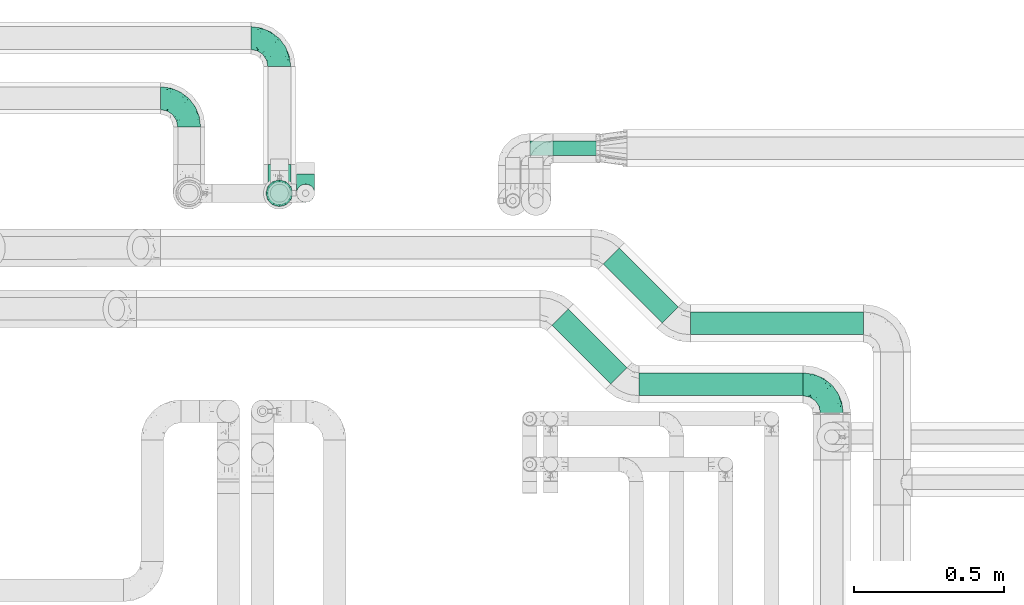
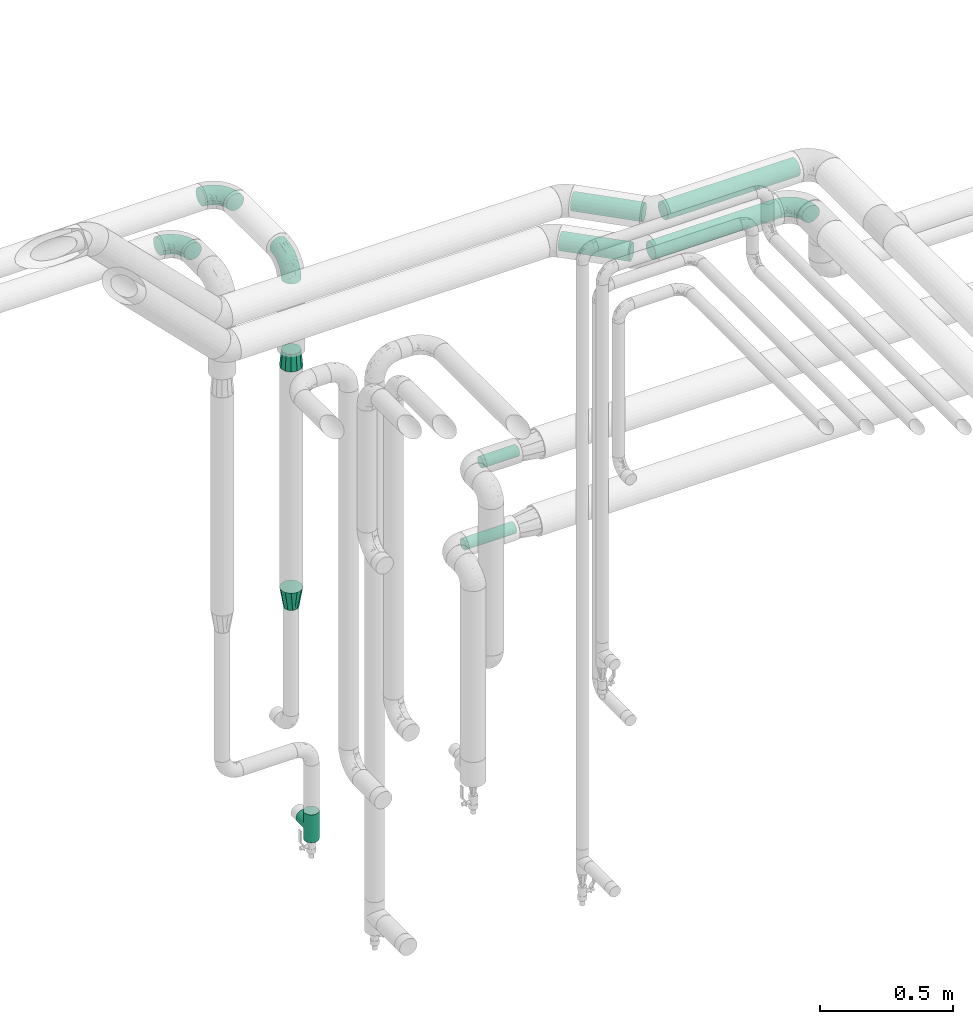
# One storey, part 685 of 827: 7 flow fittings, 6 flow segments.
"""IFC2X3 building model written with IfcOpenShell, lengths in millimetres."""

import ifcopenshell
import ifcopenshell.guid

model = None  # the IFC model being written
_history = None  # IfcOwnerHistory: only IFC2X3 demands one
_inside = {}  # id of a spatial element -> (the spatial element, [elements in it])
_under = {}  # id of a project, library or spatial element -> (it, [spatial elements below it])
_declared = {}  # id of a project -> (the project, [libraries it declares])
_typed = {}  # id of a type object -> (the type object, [elements of that type])
_made_of = {}  # id of a material, layer set ... -> (it, [elements and type objects made of it])


def new_model(schema):
    """Start an empty IFC model of exactly this schema.

    Asked for "IFC4X3", IfcOpenShell would pick the latest addendum, in which some entities
    have other attributes; the version numbers below select the first issue.
    IFC2X3 requires an IfcOwnerHistory on every rooted entity: one is made here for all.
    """
    global model, _history
    if schema == "IFC4X3":
        model = ifcopenshell.file(schema_version=(4, 3, 0, 0))
    else:
        model = ifcopenshell.file(schema=schema)
    _inside.clear()
    _under.clear()
    _declared.clear()
    _typed.clear()
    _made_of.clear()
    _history = None
    if model.schema == "IFC2X3":
        org = make("IfcOrganization", Name="unknown")
        user = make(
            "IfcPersonAndOrganization",
            ThePerson=make("IfcPerson", FamilyName="unknown"),
            TheOrganization=org,
        )
        app = make(
            "IfcApplication",
            ApplicationDeveloper=org,
            Version="unknown",
            ApplicationFullName="unknown",
            ApplicationIdentifier="unknown",
        )
        _history = make(
            "IfcOwnerHistory",
            OwningUser=user,
            OwningApplication=app,
            ChangeAction="ADDED",
            CreationDate=0,
        )
    return model


def make(cls, **values):
    """One entity of the class cls with the attributes given. An attribute that is None is left unset."""
    return model.create_entity(
        cls, **{name: value for name, value in values.items() if value is not None}
    )


def entity(cls, *values):
    """Any entity or typed value of the class cls, its attributes in the order of the schema. None: left unset."""
    e = model.create_entity(cls)
    for i, value in enumerate(values):
        if value is not None:
            e[i] = value
    return e


def rooted(cls, **values):
    """An entity with a GlobalId (a new one), such as an element, a storey or a relation."""
    return make(cls, GlobalId=ifcopenshell.guid.new(), OwnerHistory=_history, **values)


def si_unit(unit_type, name, prefix=None):
    """IfcSIUnit, for example si_unit("LENGTHUNIT", "METRE", prefix="MILLI")."""
    return make("IfcSIUnit", UnitType=unit_type, Prefix=prefix, Name=name)


def converted_unit(unit_type, name, factor, base, dimensions=None, offset=None):
    """IfcConversionBasedUnit, such as the inch: factor (a typed value) times the base unit."""
    return make(
        "IfcConversionBasedUnit"
        if offset is None
        else "IfcConversionBasedUnitWithOffset",
        ConversionOffset=offset,
        Dimensions=None
        if dimensions is None
        else entity("IfcDimensionalExponents", *dimensions),
        UnitType=unit_type,
        Name=name,
        ConversionFactor=make(
            "IfcMeasureWithUnit", ValueComponent=factor, UnitComponent=base
        ),
    )


def derived_unit(unit_type, elements):
    """IfcDerivedUnit: a product of units, each with its exponent."""
    return make(
        "IfcDerivedUnit",
        Elements=[
            make("IfcDerivedUnitElement", Unit=unit, Exponent=power)
            for unit, power in elements
        ],
        UnitType=unit_type,
    )


def assignment(units):
    """IfcUnitAssignment: the units of a project."""
    return None if units is None else make("IfcUnitAssignment", Units=units)


def point(xyz):
    """IfcCartesianPoint."""
    return None if xyz is None else make("IfcCartesianPoint", Coordinates=xyz)


def direction(xyz):
    """IfcDirection."""
    return None if xyz is None else make("IfcDirection", DirectionRatios=xyz)


def frame(location, z_axis=None, x_axis=None):
    """IfcAxis2Placement3D, a coordinate frame: its origin and axes. An axis left out is left unset."""
    return make(
        "IfcAxis2Placement3D",
        Location=point(location),
        Axis=direction(z_axis),
        RefDirection=direction(x_axis),
    )


def frame_2d(location, x_axis=None):
    """IfcAxis2Placement2D, a coordinate frame in the plane: its origin and x axis."""
    return make(
        "IfcAxis2Placement2D", Location=point(location), RefDirection=direction(x_axis)
    )


def origin():
    """The frame at (0, 0, 0) with its axes left unset."""
    return frame((0.0, 0.0, 0.0))


def origin_2d_with_axis():
    """The frame at (0, 0) in the plane with the x axis (1, 0) written out."""
    return frame_2d((0.0, 0.0), x_axis=(1.0, 0.0))


def place(relative_to, where):
    """IfcLocalPlacement: puts the frame where relative to a parent placement (None: the world)."""
    return make(
        "IfcLocalPlacement", PlacementRelTo=relative_to, RelativePlacement=where
    )


def context(
    kind, dimensions, precision=None, world=None, true_north=None, identifier=None
):
    """IfcGeometricRepresentationContext, for example the 3D "Model" context."""
    return make(
        "IfcGeometricRepresentationContext",
        ContextIdentifier=identifier,
        ContextType=kind,
        CoordinateSpaceDimension=dimensions,
        Precision=precision,
        WorldCoordinateSystem=world,
        TrueNorth=true_north,
    )


def subcontext(parent, identifier, kind, view, scale=None):
    """IfcGeometricRepresentationSubContext, for example "Body" below "Model"."""
    return make(
        "IfcGeometricRepresentationSubContext",
        ContextIdentifier=identifier,
        ContextType=kind,
        ParentContext=parent,
        TargetScale=scale,
        TargetView=view,
    )


def project(units=None, contexts=None):
    """IfcProject with its units and contexts."""
    return rooted(
        "IfcProject",
        Name="project",
        RepresentationContexts=contexts,
        UnitsInContext=assignment(units),
    )


def spatial(cls, under=None, at=None, **own):
    """A site, building, storey or space (cls), placed at a placement, below another one or the project."""
    s = rooted(cls, ObjectPlacement=at, **own)
    if under is not None:
        _under.setdefault(under.id(), (under, []))[1].append(s)
    return s


def profile(cls, at=None, kind="AREA", **sizes):
    """A parametric profile (cls). Its sizes go by their IFC names, for example OverallWidth=200.0."""
    return make(cls, ProfileType=kind, Position=at, **sizes)


def circle(**sizes):
    """IfcCircleProfileDef."""
    return profile("IfcCircleProfileDef", **sizes)


def extrude(swept, where, along, depth):
    """IfcExtrudedAreaSolid: the profile swept, set in the frame where, extruded along a direction by depth."""
    return make(
        "IfcExtrudedAreaSolid",
        SweptArea=swept,
        Position=where,
        ExtrudedDirection=direction(along),
        Depth=depth,
    )


def faces_of(points, faces, orient=None, outer=None):
    """IfcFace entities. A face is a list of loops; a loop is a list of indices into points, from 0.

    orient and outer hold one flag for each loop. By default every Orientation is true, the
    first loop of a face is its IfcFaceOuterBound and the others are IfcFaceBound.
    """
    made = []
    for i, loops in enumerate(faces):
        bounds = []
        for j, loop in enumerate(loops):
            is_outer = j == 0 if outer is None else outer[i][j]
            bounds.append(
                make(
                    "IfcFaceOuterBound" if is_outer else "IfcFaceBound",
                    Bound=make("IfcPolyLoop", Polygon=[points[k] for k in loop]),
                    Orientation=True if orient is None else orient[i][j],
                )
            )
        made.append(make("IfcFace", Bounds=bounds))
    return made


def faceted_brep(points, faces, orient=None, outer=None, voids=None):
    """IfcFacetedBrep: a solid bounded by flat faces; with voids (closed shells), ...WithVoids."""
    shared = [point(p) for p in points]
    hull = make("IfcClosedShell", CfsFaces=faces_of(shared, faces, orient, outer))
    if voids is None:
        return make("IfcFacetedBrep", Outer=hull)
    return make(
        "IfcFacetedBrepWithVoids",
        Outer=hull,
        Voids=[
            make(cls, CfsFaces=faces_of(shared, fs, o, b)) for cls, fs, o, b in voids
        ],
    )


def shape(context_of_items, identifier, shape_type, items):
    """IfcShapeRepresentation: the items that make up one representation, for example the "Body"."""
    return make(
        "IfcShapeRepresentation",
        ContextOfItems=context_of_items,
        RepresentationIdentifier=identifier,
        RepresentationType=shape_type,
        Items=items,
    )


def source(mapping_origin, context_of_items, identifier, shape_type, items):
    """IfcRepresentationMap: a shape defined once, which mapped items show again and again."""
    return make(
        "IfcRepresentationMap",
        MappingOrigin=mapping_origin,
        MappedRepresentation=shape(context_of_items, identifier, shape_type, items),
    )


def transform(
    local_origin,
    x_axis=None,
    y_axis=None,
    z_axis=None,
    scale=None,
    scale2=None,
    scale3=None,
    uniform=True,
):
    """IfcCartesianTransformationOperator3D, or its non-uniform kind. x_axis, y_axis, z_axis: its Axis1, 2, 3."""
    if uniform:
        return make(
            "IfcCartesianTransformationOperator3D",
            Axis1=direction(x_axis),
            Axis2=direction(y_axis),
            LocalOrigin=point(local_origin),
            Scale=scale,
            Axis3=direction(z_axis),
        )
    return make(
        "IfcCartesianTransformationOperator3DnonUniform",
        Axis1=direction(x_axis),
        Axis2=direction(y_axis),
        LocalOrigin=point(local_origin),
        Scale=scale,
        Axis3=direction(z_axis),
        Scale2=scale2,
        Scale3=scale3,
    )


def mapped(mapping_source, mapping_target):
    """IfcMappedItem: shows the shape of a source again, moved by a transform."""
    return make(
        "IfcMappedItem", MappingSource=mapping_source, MappingTarget=mapping_target
    )


def material(Name=None, Category=None):
    """IfcMaterial."""
    return make("IfcMaterial", Name=Name, Category=Category)


def made_of(thing, what):
    """Note that an element or type object is made of a material, layer set ...; save() writes the relation."""
    if what is not None:
        _made_of.setdefault(what.id(), (what, []))[1].append(thing)
    return thing


def type_object(cls, material=None, **own):
    """A type object (cls), such as IfcWallType, which elements share."""
    return made_of(rooted(cls, **own), material)


def type_shapes(of_type, sources):
    """Give a type object the sources (RepresentationMaps) that its elements show as mapped items."""
    of_type.RepresentationMaps = sources


def element(
    cls,
    number,
    at=None,
    inside=None,
    cuts=None,
    type_object=None,
    material=None,
    context=None,
    identifier="Body",
    shape_type=None,
    held_by="IfcProductDefinitionShape",
    body=None,
    shapes=None,
    **own,
):
    """One element of the class cls, such as IfcWall. Its Tag is "e" and its number.

    at: its placement. inside: the storey or other place that contains it. cuts: it is an
    opening in that element (IfcRelVoidsElement). A single representation is given by context,
    identifier, shape_type and body (its items); several are given by shapes. held_by: the class
    of the entity that holds the representations. save() writes the other relations.
    """
    e = rooted(cls, Tag="e%d" % number, ObjectPlacement=at, **own)
    if body is not None:
        shapes = [shape(context, identifier, shape_type, body)]
    if shapes is not None:
        e.Representation = make(held_by, Representations=shapes)
    if inside is not None:
        _inside.setdefault(inside.id(), (inside, []))[1].append(e)
    if cuts is not None:
        rooted(
            "IfcRelVoidsElement", RelatingBuildingElement=cuts, RelatedOpeningElement=e
        )
    if type_object is not None:
        _typed.setdefault(type_object.id(), (type_object, []))[1].append(e)
    return made_of(e, material)


def aggregate(whole, parts):
    """IfcRelAggregates: a whole, such as a stair, and the parts it consists of."""
    return rooted("IfcRelAggregates", RelatingObject=whole, RelatedObjects=parts)


def save(model, path):
    """Write the relations noted so far, then the file.

    IfcRelAggregates (storeys below a building ...), IfcRelContainedInSpatialStructure (elements
    in a storey), IfcRelDefinesByType, IfcRelAssociatesMaterial and IfcRelDeclares: one each for
    every whole, place, type object, material and project.
    """
    for whole, parts in _under.values():
        aggregate(whole, parts)
    for where, things in _inside.values():
        rooted(
            "IfcRelContainedInSpatialStructure",
            RelatedElements=things,
            RelatingStructure=where,
        )
    for kind, things in _typed.values():
        rooted("IfcRelDefinesByType", RelatedObjects=things, RelatingType=kind)
    for what, things in _made_of.values():
        rooted("IfcRelAssociatesMaterial", RelatedObjects=things, RelatingMaterial=what)
    for by, libraries in _declared.values():
        rooted("IfcRelDeclares", RelatingContext=by, RelatedDefinitions=libraries)
    model.write(path)


model = new_model("IFC2X3")

# Units and contexts
model_context = context("Model", 3, precision=0.01, world=origin(), true_north=direction((6.12303176911189e-17, 1.0)))
body_context = subcontext(model_context, "Body", "Model", "MODEL_VIEW")
ifc_project = project(units=[si_unit("LENGTHUNIT", "METRE", prefix="MILLI"), si_unit("AREAUNIT", "SQUARE_METRE"), si_unit("VOLUMEUNIT", "CUBIC_METRE"), converted_unit("PLANEANGLEUNIT", "DEGREE", entity("IfcRatioMeasure", 0.0174532925199433), si_unit("PLANEANGLEUNIT", "RADIAN"), dimensions=[0, 0, 0, 0, 0, 0, 0]), si_unit("MASSUNIT", "GRAM", prefix="KILO"), derived_unit("MASSDENSITYUNIT", [(si_unit("MASSUNIT", "GRAM", prefix="KILO"), 1), (si_unit("LENGTHUNIT", "METRE"), -3)]), derived_unit("MOMENTOFINERTIAUNIT", [(si_unit("LENGTHUNIT", "METRE"), 4)]), si_unit("TIMEUNIT", "SECOND"), si_unit("FREQUENCYUNIT", "HERTZ"), si_unit("THERMODYNAMICTEMPERATUREUNIT", "DEGREE_CELSIUS"), derived_unit("THERMALTRANSMITTANCEUNIT", [(si_unit("MASSUNIT", "GRAM", prefix="KILO"), 1), (si_unit("THERMODYNAMICTEMPERATUREUNIT", "KELVIN"), -1), (si_unit("TIMEUNIT", "SECOND"), -3)]), derived_unit("VOLUMETRICFLOWRATEUNIT", [(si_unit("LENGTHUNIT", "METRE"), 3), (si_unit("TIMEUNIT", "SECOND"), -1)]), derived_unit("MASSFLOWRATEUNIT", [(si_unit("MASSUNIT", "GRAM", prefix="KILO"), 1), (si_unit("TIMEUNIT", "SECOND"), -1)]), derived_unit("ROTATIONALFREQUENCYUNIT", [(si_unit("TIMEUNIT", "SECOND"), -1)]), si_unit("ELECTRICCURRENTUNIT", "AMPERE"), si_unit("ELECTRICVOLTAGEUNIT", "VOLT"), si_unit("POWERUNIT", "WATT"), si_unit("FORCEUNIT", "NEWTON", prefix="KILO"), si_unit("ILLUMINANCEUNIT", "LUX"), si_unit("LUMINOUSFLUXUNIT", "LUMEN"), si_unit("LUMINOUSINTENSITYUNIT", "CANDELA"), derived_unit("USERDEFINED", [(si_unit("MASSUNIT", "GRAM", prefix="KILO"), -1), (si_unit("LENGTHUNIT", "METRE"), -2), (si_unit("TIMEUNIT", "SECOND"), 3), (si_unit("LUMINOUSFLUXUNIT", "LUMEN"), 1)]), derived_unit("LINEARVELOCITYUNIT", [(si_unit("LENGTHUNIT", "METRE"), 1), (si_unit("TIMEUNIT", "SECOND"), -1)]), si_unit("PRESSUREUNIT", "PASCAL"), derived_unit("USERDEFINED", [(si_unit("LENGTHUNIT", "METRE"), -2), (si_unit("MASSUNIT", "GRAM", prefix="KILO"), 1), (si_unit("TIMEUNIT", "SECOND"), -2)]), derived_unit("LINEARFORCEUNIT", [(si_unit("MASSUNIT", "GRAM", prefix="KILO"), 1), (si_unit("LENGTHUNIT", "METRE"), 1), (si_unit("TIMEUNIT", "SECOND"), -2), (si_unit("LENGTHUNIT", "METRE"), -1)]), derived_unit("PLANARFORCEUNIT", [(si_unit("MASSUNIT", "GRAM", prefix="KILO"), 1), (si_unit("LENGTHUNIT", "METRE"), 1), (si_unit("TIMEUNIT", "SECOND"), -2), (si_unit("LENGTHUNIT", "METRE"), -2)])], contexts=[model_context])

# Site, building, storey
site_placement = place(None, origin())
site = spatial("IfcSite", under=ifc_project, at=site_placement, CompositionType="ELEMENT")
building_placement = place(site_placement, origin())
building = spatial("IfcBuilding", under=site, at=building_placement, CompositionType="ELEMENT")
storey_placement = place(building_placement, frame((0.0, 0.0, 28200.0)))
storey = spatial("IfcBuildingStorey", under=building, at=storey_placement, Name="08", CompositionType="ELEMENT", Elevation=28200.0)

# Flow segments
pipe_segment_type = type_object("IfcPipeSegmentType", PredefinedType="NOTDEFINED")
flow_segment_1_placement = place(storey_placement, frame((48004.19, 18316.33, 2960.65)))
element("IfcFlowSegment", 1, at=flow_segment_1_placement, inside=storey, type_object=pipe_segment_type, context=body_context, shape_type="SweptSolid", body=[
    extrude(circle(Radius=37.75, at=origin_2d_with_axis()), frame((0.0, 39.35, 39.35), z_axis=(1.0, 0.0, 0.0), x_axis=(0.0, 1.0, 0.0)), (0.0, 0.0, 1.0), 545.649711574547),
])
flow_segment_2_placement = place(storey_placement, frame((47713.36, 18355.21, 2960.65)))
element("IfcFlowSegment", 2, at=flow_segment_2_placement, inside=storey, type_object=pipe_segment_type, context=body_context, shape_type="SweptSolid", body=[
    extrude(circle(Radius=37.75, at=origin_2d_with_axis()), frame((28.29, 223.66, 39.35), z_axis=(0.707106781186555, -0.70710678118654, 0.0), x_axis=(0.70710678118654, 0.707106781186555, 0.0)), (0.0, 0.0, 1.0), 276.299423149123),
])
flow_segment_3_placement = place(storey_placement, frame((48174.38, 18519.16, 2960.65)))
element("IfcFlowSegment", 3, at=flow_segment_3_placement, inside=storey, type_object=pipe_segment_type, context=body_context, shape_type="SweptSolid", body=[
    extrude(circle(Radius=37.75, at=origin_2d_with_axis()), frame((0.0, 39.35, 39.35), z_axis=(1.0, 0.0, 0.0), x_axis=(0.0, 1.0, 0.0)), (0.0, 0.0, 1.0), 575.649711574558),
])
flow_segment_4_placement = place(storey_placement, frame((47883.25, 18558.04, 2960.65)))
element("IfcFlowSegment", 4, at=flow_segment_4_placement, inside=storey, type_object=pipe_segment_type, context=body_context, shape_type="SweptSolid", body=[
    extrude(circle(Radius=37.75, at=origin_2d_with_axis()), frame((28.29, 223.96, 39.35), z_axis=(0.707106781186485, -0.70710678118661, 0.0), x_axis=(0.70710678118661, 0.707106781186485, 0.0)), (0.0, 0.0, 1.0), 276.715492530283),
])
flow_segment_5_placement = place(storey_placement, frame((47641.3, 19115.63, 1274.4)))
element("IfcFlowSegment", 5, at=flow_segment_5_placement, inside=storey, type_object=pipe_segment_type, context=body_context, shape_type="SweptSolid", body=[
    extrude(circle(Radius=24.0, at=origin_2d_with_axis()), frame((0.0, 25.6, 25.6), z_axis=(1.0, 0.0, 0.0), x_axis=(0.0, 1.0, 0.0)), (0.0, 0.0, 1.0), 220.000000000002),
])
flow_segment_6_placement = place(storey_placement, frame((47718.17, 19115.63, 1624.4)))
element("IfcFlowSegment", 6, at=flow_segment_6_placement, inside=storey, type_object=pipe_segment_type, context=body_context, shape_type="SweptSolid", body=[
    extrude(circle(Radius=24.0, at=origin_2d_with_axis()), frame((0.0, 25.6, 25.6), z_axis=(1.0, 0.0, 0.0), x_axis=(0.0, 1.0, 0.0)), (0.0, 0.0, 1.0), 156.125000000036),
])

# Flow fittings
ifc_material = material()
pipe_fitting_type_1 = type_object("IfcPipeFittingType", Name="ADSK_1", PredefinedType="NOTDEFINED", material=ifc_material)
shared_shape_1 = source(origin(), body_context, "Body", "Brep", [
    faceted_brep([(-95.0, 19.02, -32.95), (-95.0, 9.85, -36.75), (-95.0, 0.0, -38.05), (-95.0, -9.85, -36.75), (-95.0, -19.03, -32.95), (-95.0, -26.91, -26.91), (-95.0, -32.95, -19.03), (-95.0, -36.75, -9.85), (-95.0, -38.05, 0.0), (-95.0, -36.75, 9.85), (-95.0, -32.95, 19.02), (-95.0, -26.91, 26.91), (-95.0, -19.03, 32.95), (-95.0, -9.85, 36.75), (-95.0, 0.0, 38.05), (-95.0, 9.85, 36.75), (-95.0, 19.02, 32.95), (-95.0, 26.91, 26.91), (-95.0, 32.95, 19.02), (-95.0, 36.75, 9.85), (-95.0, 38.05, 0.0), (-95.0, 36.75, -9.85), (-95.0, 32.95, -19.03), (-95.0, 26.91, -26.91), (0.0, 95.0, -38.05), (-9.85, 95.0, -36.75), (-19.02, 95.0, -32.95), (-26.91, 95.0, -26.91), (-32.95, 95.0, -19.03), (-36.75, 95.0, -9.85), (-38.05, 95.0, 0.0), (-36.75, 95.0, 9.85), (-32.95, 95.0, 19.02), (-26.91, 95.0, 26.91), (-19.02, 95.0, 32.95), (-9.85, 95.0, 36.75), (0.0, 95.0, 38.05), (9.85, 95.0, 36.75), (19.03, 95.0, 32.95), (26.91, 95.0, 26.91), (32.95, 95.0, 19.02), (36.75, 95.0, 9.85), (38.05, 95.0, 0.0), (36.75, 95.0, -9.85), (32.95, 95.0, -19.03), (26.91, 95.0, -26.91), (19.03, 95.0, -32.95), (9.85, 95.0, -36.75), (-7.99, -4.96, 6.3), (-0.92, 0.92, 0.0), (4.62, 8.1, 8.01), (-76.19, -35.57, 0.0), (-64.32, -32.32, 12.43), (20.51, 62.45, 28.68), (-60.56, -33.52, 0.0), (-70.4, -13.47, 34.42), (-39.61, -5.88, 32.32), (-49.6, 2.07, 37.1), (-70.34, -28.81, 21.71), (14.64, 40.81, 26.5), (5.88, 39.61, 32.32), (3.59, 20.77, 25.31), (-40.45, 68.06, 16.75), (-62.45, -20.51, 28.68), (-44.52, -26.87, 0.0), (-28.47, -20.22, 0.0), (-26.43, -17.83, 8.75), (-76.1, 39.63, 10.76), (-72.74, 37.58, 18.19), (-60.35, 46.18, 14.61), (-13.4, 13.4, 32.12), (-20.77, -3.59, 25.31), (-14.66, 81.47, 35.56), (-6.22, 71.26, 37.92), (-57.5, 42.48, 22.79), (-15.0, 34.74, 37.7), (-27.1, 12.08, 36.05), (-9.2, 28.81, 35.63), (-79.98, 23.7, 30.95), (-73.68, -4.3, 37.48), (-30.74, 21.67, 37.97), (-62.36, 47.59, 6.79), (-72.71, 32.83, 24.69), (-67.42, 7.02, 37.95), (-32.13, 75.27, 24.51), (-43.46, 51.47, 26.26), (-24.98, 73.15, 31.29), (20.59, 41.28, 19.85), (7.79, 16.09, 15.86), (-73.21, 42.39, 0.0), (-54.73, 54.73, 0.0), (-73.44, 15.79, 35.79), (-5.94, 4.32, 20.43), (28.81, 70.34, 21.71), (32.32, 64.32, 12.43), (-53.59, 26.2, 35.09), (-52.02, 19.31, 37.21), (21.38, 33.53, 10.34), (26.87, 44.52, 0.0), (-48.28, 12.14, 38.05), (4.3, 73.68, 37.48), (-44.08, -25.52, 12.79), (-41.28, -20.59, 19.85), (35.57, 76.19, 0.0), (-47.26, 54.3, 20.18), (-47.4, 61.99, 8.58), (-42.39, 73.21, 0.0), (-39.67, 78.86, 7.21), (-45.69, 36.84, 33.11), (-32.83, 50.13, 33.35), (13.47, 70.4, 34.42), (-18.25, 63.73, 36.07), (-40.63, -13.75, 27.22), (-16.63, 46.37, 37.95), (-53.47, 38.79, 28.59), (-26.07, 48.54, 36.15), (-34.51, 34.51, 36.86), (-2.07, 49.6, 37.1), (-22.79, -10.49, 19.23), (-61.73, 28.67, 31.87), (9.65, 14.7, 0.0), (20.22, 28.47, 0.0), (33.52, 60.56, 0.0), (-11.42, -5.44, 13.25), (-14.7, -9.65, 0.0), (-81.47, 14.66, -35.56), (-62.45, -20.51, -28.68), (-71.26, 6.22, -37.92), (-75.27, 32.13, -24.51), (-73.15, 24.98, -31.29), (13.47, 70.4, -34.42), (5.88, 39.61, -32.32), (-2.07, 49.6, -37.1), (-78.86, 39.67, -7.21), (-70.4, -13.47, -34.42), (-39.61, -5.88, -32.32), (-61.99, 47.4, -8.58), (32.32, 64.32, -12.43), (28.81, 70.34, -21.71), (-63.73, 18.25, -36.07), (-50.13, 32.83, -33.35), (4.3, 73.68, -37.48), (-7.02, 67.42, -37.95), (-39.63, 76.1, -10.76), (-46.18, 60.35, -14.61), (-47.59, 62.36, -6.79), (-64.32, -32.32, -12.43), (-26.2, 53.59, -35.09), (-15.79, 73.44, -35.79), (-19.31, 52.02, -37.21), (-37.58, 72.74, -18.19), (-70.34, -28.81, -21.71), (-42.48, 57.5, -22.79), (-38.79, 53.47, -28.59), (-51.47, 43.46, -26.26), (-32.83, 72.71, -24.69), (-46.37, 16.63, -37.95), (-73.68, -4.3, -37.48), (-41.28, -20.59, -19.85), (-44.08, -25.52, -12.79), (13.75, 40.63, -27.22), (20.51, 62.45, -28.68), (-68.06, 40.45, -16.75), (-54.3, 47.26, -20.18), (-12.14, 48.28, -38.05), (-21.67, 30.74, -37.97), (-36.84, 45.69, -33.11), (-11.42, -5.44, -13.25), (7.79, 16.09, -15.86), (4.62, 8.1, -8.01), (-23.7, 79.98, -30.95), (-26.43, -17.83, -8.75), (-7.99, -4.96, -6.3), (-40.81, -14.64, -26.5), (-20.77, -3.59, -25.31), (-34.74, 15.0, -37.7), (-12.08, 27.1, -36.05), (-28.81, 9.2, -35.63), (-22.79, -10.49, -19.23), (21.38, 33.53, -10.34), (20.59, 41.28, -19.85), (-48.54, 26.07, -36.15), (-49.6, 2.07, -37.1), (-13.4, 13.4, -32.12), (3.59, 20.77, -25.31), (-28.67, 61.73, -31.87), (-34.51, 34.51, -36.86), (-5.94, 4.32, -20.43)], [[[0, 1, 2, 3, 4, 5, 6, 7, 8, 9, 10, 11, 12, 13, 14, 15, 16, 17, 18, 19, 20, 21, 22, 23]], [[24, 25, 26, 27, 28, 29, 30, 31, 32, 33, 34, 35, 36, 37, 38, 39, 40, 41, 42, 43, 44, 45, 46, 47]], [[48, 49, 50]], [[51, 52, 9]], [[53, 39, 38]], [[9, 52, 10]], [[54, 52, 51]], [[55, 56, 57]], [[11, 10, 58]], [[59, 60, 61]], [[32, 31, 62]], [[63, 12, 11]], [[63, 55, 12]], [[64, 65, 66]], [[67, 68, 69]], [[70, 56, 71]], [[35, 72, 73]], [[69, 68, 74]], [[75, 76, 77]], [[16, 78, 17]], [[13, 79, 14]], [[76, 75, 80]], [[67, 69, 81]], [[18, 17, 82]], [[14, 79, 83]], [[20, 19, 67]], [[84, 85, 86]], [[87, 61, 88]], [[89, 81, 90]], [[18, 82, 68]], [[15, 91, 16]], [[14, 83, 15]], [[71, 92, 61]], [[17, 78, 82]], [[93, 87, 94]], [[95, 91, 96]], [[97, 98, 94]], [[86, 72, 34]], [[96, 99, 80]], [[37, 36, 100]], [[40, 39, 93]], [[40, 94, 41]], [[64, 66, 101]], [[93, 94, 40]], [[58, 102, 63]], [[94, 103, 41]], [[94, 87, 97]], [[104, 69, 74]], [[34, 33, 86]], [[105, 69, 104]], [[52, 58, 10]], [[106, 107, 30]], [[108, 109, 85]], [[105, 106, 90]], [[53, 110, 60]], [[86, 111, 72]], [[86, 109, 111]], [[33, 84, 86]], [[12, 55, 13]], [[112, 56, 63]], [[110, 38, 37]], [[34, 72, 35]], [[36, 35, 73]], [[111, 113, 73]], [[105, 107, 106]], [[110, 53, 38]], [[74, 114, 85]], [[91, 15, 83]], [[105, 90, 81]], [[107, 62, 31]], [[33, 32, 84]], [[115, 109, 116]], [[111, 115, 113]], [[100, 73, 117]], [[56, 55, 63]], [[79, 55, 57]], [[102, 118, 112]], [[56, 70, 76]], [[100, 110, 37]], [[117, 77, 60]], [[117, 60, 110]], [[60, 70, 61]], [[58, 52, 101]], [[63, 11, 58]], [[39, 53, 93]], [[87, 93, 53]], [[96, 91, 83]], [[78, 91, 119]], [[32, 62, 84]], [[84, 62, 104]], [[86, 85, 109]], [[85, 114, 108]], [[80, 113, 116]], [[117, 73, 113]], [[80, 116, 96]], [[80, 57, 76]], [[71, 112, 118]], [[61, 87, 59]], [[62, 107, 105]], [[97, 120, 121]], [[70, 71, 61]], [[71, 118, 92]], [[73, 100, 36]], [[110, 100, 117]], [[55, 79, 13]], [[83, 79, 57]], [[96, 83, 99]], [[116, 108, 95]], [[50, 97, 88]], [[97, 87, 88]], [[50, 49, 120]], [[122, 94, 98]], [[89, 20, 67]], [[105, 81, 69]], [[89, 67, 81]], [[68, 19, 18]], [[68, 67, 19]], [[74, 68, 82]], [[114, 82, 119]], [[74, 85, 104]], [[82, 114, 74]], [[114, 119, 108]], [[95, 108, 119]], [[116, 109, 108]], [[123, 48, 50]], [[97, 50, 120]], [[123, 50, 88]], [[91, 95, 119]], [[116, 95, 96]], [[84, 104, 85]], [[104, 62, 105]], [[83, 57, 99]], [[57, 80, 99]], [[66, 48, 123]], [[66, 124, 48]], [[118, 66, 123]], [[124, 66, 65]], [[66, 118, 101]], [[54, 64, 52]], [[124, 49, 48]], [[30, 107, 31]], [[91, 78, 16]], [[82, 78, 119]], [[56, 76, 57]], [[77, 76, 70]], [[60, 77, 70]], [[77, 117, 75]], [[117, 113, 75]], [[113, 80, 75]], [[9, 8, 51]], [[103, 94, 122]], [[103, 42, 41]], [[73, 72, 111]], [[113, 115, 116]], [[111, 109, 115]], [[102, 112, 63]], [[71, 56, 112]], [[118, 102, 101]], [[92, 123, 88]], [[123, 92, 118]], [[61, 92, 88]], [[87, 53, 59]], [[60, 59, 53]], [[97, 121, 98]], [[58, 101, 102]], [[64, 101, 52]], [[125, 1, 0]], [[126, 5, 4]], [[2, 1, 127]], [[1, 125, 127]], [[128, 129, 23]], [[130, 131, 132]], [[89, 133, 20]], [[126, 134, 135]], [[136, 89, 90]], [[137, 138, 44]], [[139, 129, 140]], [[24, 141, 142]], [[143, 144, 145]], [[125, 129, 139]], [[6, 146, 7]], [[147, 148, 149]], [[146, 51, 7]], [[143, 150, 144]], [[146, 6, 151]], [[152, 153, 154]], [[126, 4, 134]], [[0, 23, 129]], [[28, 155, 150]], [[43, 42, 103]], [[54, 146, 64]], [[139, 156, 127]], [[157, 3, 2]], [[151, 158, 159]], [[160, 131, 161]], [[22, 21, 162]], [[136, 144, 163]], [[149, 164, 165]], [[24, 142, 25]], [[166, 140, 154]], [[154, 129, 128]], [[143, 30, 29]], [[167, 168, 169]], [[155, 28, 27]], [[26, 170, 27]], [[171, 167, 172]], [[26, 25, 148]], [[27, 170, 155]], [[173, 135, 174]], [[144, 150, 152]], [[175, 176, 177]], [[24, 47, 141]], [[45, 161, 46]], [[148, 25, 142]], [[176, 175, 165]], [[64, 159, 171]], [[138, 45, 44]], [[130, 46, 161]], [[137, 44, 43]], [[178, 159, 158]], [[137, 103, 122]], [[163, 144, 152]], [[136, 133, 89]], [[103, 137, 43]], [[6, 5, 151]], [[178, 158, 173]], [[134, 4, 3]], [[178, 173, 174]], [[137, 98, 179]], [[145, 90, 106]], [[138, 180, 161]], [[46, 130, 47]], [[136, 90, 145]], [[133, 162, 21]], [[23, 22, 128]], [[139, 140, 181]], [[139, 181, 156]], [[157, 127, 182]], [[157, 134, 3]], [[182, 177, 135]], [[182, 135, 134]], [[135, 183, 174]], [[131, 130, 161]], [[141, 130, 132]], [[160, 180, 184]], [[131, 183, 176]], [[5, 126, 151]], [[158, 151, 126]], [[180, 138, 137]], [[161, 45, 138]], [[149, 148, 142]], [[170, 148, 185]], [[22, 162, 128]], [[128, 162, 163]], [[129, 154, 140]], [[154, 153, 166]], [[165, 156, 186]], [[182, 127, 156]], [[165, 186, 149]], [[165, 132, 176]], [[131, 184, 183]], [[187, 167, 178]], [[184, 168, 187]], [[167, 169, 172]], [[184, 180, 168]], [[174, 183, 184]], [[127, 157, 2]], [[134, 157, 182]], [[130, 141, 47]], [[142, 141, 132]], [[149, 142, 164]], [[186, 166, 147]], [[180, 179, 168]], [[169, 179, 120]], [[137, 179, 180]], [[179, 121, 120]], [[106, 30, 143]], [[136, 145, 144]], [[106, 143, 145]], [[150, 29, 28]], [[150, 143, 29]], [[152, 150, 155]], [[153, 155, 185]], [[152, 154, 163]], [[155, 153, 152]], [[153, 185, 166]], [[147, 166, 185]], [[186, 140, 166]], [[169, 120, 49]], [[169, 49, 172]], [[179, 169, 168]], [[148, 147, 185]], [[186, 147, 149]], [[128, 163, 154]], [[163, 162, 136]], [[142, 132, 164]], [[132, 165, 164]], [[171, 124, 65]], [[124, 171, 172]], [[64, 146, 159]], [[171, 159, 178]], [[171, 65, 64]], [[172, 49, 124]], [[162, 133, 136]], [[20, 133, 21]], [[148, 170, 26]], [[155, 170, 185]], [[131, 176, 132]], [[177, 176, 183]], [[135, 177, 183]], [[177, 182, 175]], [[182, 156, 175]], [[156, 165, 175]], [[51, 146, 54]], [[51, 8, 7]], [[129, 125, 0]], [[127, 125, 139]], [[140, 186, 181]], [[156, 181, 186]], [[158, 126, 173]], [[135, 173, 126]], [[187, 178, 174]], [[171, 178, 167]], [[184, 187, 174]], [[167, 187, 168]], [[180, 160, 161]], [[184, 131, 160]], [[98, 137, 122]], [[98, 121, 179]], [[151, 159, 146]]]),
])
type_shapes(pipe_fitting_type_1, [shared_shape_1])
for number, where, z_axis, x_axis, name in (
    (7, (48644.84, 18355.68, 3000.0), (0.0, 0.0, 1.0), (0.0, 1.0, 0.0), "ADSK_1"),
    (8, (46807.82, 19507.23, 3000.0), (0.0, 0.0, 1.0), (0.0, 1.0, 0.0), "ADSK_1"),
    (9, (46807.82, 18991.22, 3000.0), (1.0, 0.0, 0.0), (0.0, -1.0, 0.0), "ADSK_1"),
    (10, (46507.82, 19307.23, 3000.0), (0.0, 0.0, 1.0), (0.0, 1.0, 0.0), "ADSK_1"),
):
    element("IfcFlowFitting", number, at=place(storey_placement, frame(where, z_axis=z_axis, x_axis=x_axis)), inside=storey, type_object=pipe_fitting_type_1, material=ifc_material, Name=name, ObjectType="ADSK_1", context=body_context, shape_type="MappedRepresentation", body=[
        mapped(shared_shape_1, transform((0.0, 0.0, 0.0), scale=1.0)),
    ])
pipe_fitting_type_2 = type_object("IfcPipeFittingType", Name="ADSK_1", PredefinedType="NOTDEFINED", material=ifc_material)
shared_shape_2 = source(origin(), body_context, "Body", "Brep", [
    faceted_brep([(-64.0, 15.07, -26.11), (-64.0, 7.8, -29.12), (-64.0, 0.0, -30.15), (-64.0, -7.8, -29.12), (-64.0, -15.08, -26.11), (-64.0, -21.32, -21.32), (-64.0, -26.11, -15.08), (-64.0, -29.12, -7.8), (-64.0, -30.15, 0.0), (-64.0, -29.12, 7.8), (-64.0, -26.11, 15.07), (-64.0, -21.32, 21.32), (-64.0, -15.08, 26.11), (-64.0, -7.8, 29.12), (-64.0, 0.0, 30.15), (-64.0, 7.8, 29.12), (-64.0, 15.07, 26.11), (-64.0, 21.32, 21.32), (-64.0, 26.11, 15.07), (-64.0, 29.12, 7.8), (-64.0, 30.15, 0.0), (-64.0, 29.12, -7.8), (-64.0, 26.11, -15.08), (-64.0, 21.32, -21.32), (64.0, 0.0, -30.15), (64.0, 7.8, -29.12), (64.0, 15.07, -26.11), (64.0, 21.32, -21.32), (64.0, 26.11, -15.08), (64.0, 29.12, -7.8), (64.0, 30.15, 0.0), (64.0, 29.12, 7.8), (64.0, 26.11, 15.07), (64.0, 21.32, 21.32), (64.0, 15.07, 26.11), (64.0, 7.8, 29.12), (64.0, 0.0, 30.15), (64.0, -7.8, 29.12), (64.0, -15.08, 26.11), (64.0, -21.32, 21.32), (64.0, -26.11, 15.07), (64.0, -29.12, 7.8), (64.0, -30.15, 0.0), (64.0, -29.12, -7.8), (64.0, -26.11, -15.08), (64.0, -21.32, -21.32), (64.0, -15.08, -26.11), (64.0, -7.8, -29.12), (29.06, -29.06, 8.05), (30.15, -30.15, 0.0), (-30.15, -30.15, 0.0), (26.09, -26.09, 15.1), (16.9, -16.9, 24.97), (21.88, -21.88, 20.75), (-29.06, -29.06, 8.05), (-26.09, -26.09, 15.1), (-21.88, -21.88, 20.75), (-16.9, -16.9, 24.97), (-11.47, -11.47, 27.88), (11.47, -11.47, 27.88), (5.79, -5.79, 29.59), (0.0, 0.0, 30.15), (-5.79, -5.79, 29.59), (5.79, -5.79, -29.59), (0.0, 0.0, -30.15), (-5.79, -5.79, -29.59), (-11.47, -11.47, -27.88), (11.47, -11.47, -27.88), (16.9, -16.9, -24.97), (21.88, -21.88, -20.75), (26.09, -26.09, -15.1), (29.06, -29.06, -8.05), (-16.9, -16.9, -24.97), (-21.88, -21.88, -20.75), (-29.06, -29.06, -8.05), (-26.09, -26.09, -15.1), (0.0, -64.0, -30.15), (7.8, -64.0, -29.12), (15.08, -64.0, -26.11), (21.32, -64.0, -21.32), (26.11, -64.0, -15.08), (29.12, -64.0, -7.8), (30.15, -64.0, 0.0), (29.12, -64.0, 7.8), (26.11, -64.0, 15.07), (21.32, -64.0, 21.32), (15.08, -64.0, 26.11), (7.8, -64.0, 29.12), (0.0, -64.0, 30.15), (-7.8, -64.0, 29.12), (-15.07, -64.0, 26.11), (-21.32, -64.0, 21.32), (-26.11, -64.0, 15.07), (-29.12, -64.0, 7.8), (-30.15, -64.0, 0.0), (-29.12, -64.0, -7.8), (-26.11, -64.0, -15.08), (-21.32, -64.0, -21.32), (-15.07, -64.0, -26.11), (-7.8, -64.0, -29.12)], [[[0, 1, 2, 3, 4, 5, 6, 7, 8, 9, 10, 11, 12, 13, 14, 15, 16, 17, 18, 19, 20, 21, 22, 23]], [[24, 25, 26, 27, 28, 29, 30, 31, 32, 33, 34, 35, 36, 37, 38, 39, 40, 41, 42, 43, 44, 45, 46, 47]], [[41, 40, 48]], [[42, 41, 49]], [[50, 9, 8]], [[49, 41, 48]], [[40, 51, 48]], [[39, 38, 52]], [[51, 40, 53]], [[52, 53, 39]], [[53, 40, 39]], [[50, 54, 9]], [[9, 54, 10]], [[54, 55, 10]], [[56, 57, 11]], [[11, 10, 56]], [[11, 57, 12]], [[56, 10, 55]], [[12, 57, 58]], [[52, 38, 59]], [[60, 36, 61]], [[62, 61, 14]], [[59, 37, 60]], [[37, 59, 38]], [[60, 37, 36]], [[61, 36, 35, 15, 14]], [[32, 31, 19, 18]], [[17, 16, 34, 33]], [[18, 17, 33, 32]], [[35, 34, 16, 15]], [[20, 19, 31, 30]], [[62, 13, 58]], [[13, 62, 14]], [[58, 13, 12]], [[27, 23, 22, 28]], [[22, 21, 29, 28]], [[0, 23, 27, 26]], [[20, 30, 29, 21]], [[24, 47, 63]], [[24, 64, 2, 1, 25]], [[64, 24, 63]], [[2, 64, 65]], [[26, 25, 1, 0]], [[65, 66, 3]], [[2, 65, 3]], [[66, 4, 3]], [[63, 47, 67]], [[46, 45, 68]], [[69, 68, 45]], [[44, 70, 69]], [[69, 45, 44]], [[46, 68, 67]], [[43, 42, 49]], [[7, 50, 8]], [[43, 71, 44]], [[71, 43, 49]], [[44, 71, 70]], [[72, 4, 66]], [[72, 5, 4]], [[5, 72, 73]], [[5, 73, 6]], [[74, 50, 7]], [[75, 74, 6]], [[74, 7, 6]], [[75, 6, 73]], [[46, 67, 47]], [[76, 77, 78, 79, 80, 81, 82, 83, 84, 85, 86, 87, 88, 89, 90, 91, 92, 93, 94, 95, 96, 97, 98, 99]], [[50, 94, 93]], [[54, 50, 93]], [[91, 90, 57]], [[56, 92, 91]], [[54, 93, 92]], [[58, 90, 89]], [[55, 54, 92]], [[56, 55, 92]], [[58, 57, 90]], [[88, 61, 62]], [[58, 89, 62]], [[56, 91, 57]], [[62, 89, 88]], [[60, 88, 87]], [[86, 59, 87]], [[84, 83, 48]], [[53, 85, 84]], [[52, 86, 85]], [[49, 83, 82]], [[59, 60, 87]], [[52, 59, 86]], [[49, 48, 83]], [[51, 53, 84]], [[48, 51, 84]], [[52, 85, 53]], [[88, 60, 61]], [[82, 81, 49]], [[71, 49, 81]], [[69, 80, 79]], [[79, 78, 68]], [[71, 81, 80]], [[67, 78, 77]], [[70, 71, 80]], [[69, 70, 80]], [[67, 68, 78]], [[76, 64, 63]], [[67, 77, 63]], [[69, 79, 68]], [[63, 77, 76]], [[65, 76, 99]], [[98, 66, 99]], [[96, 95, 74]], [[73, 97, 96]], [[72, 98, 97]], [[50, 95, 94]], [[66, 65, 99]], [[72, 66, 98]], [[50, 74, 95]], [[75, 73, 96]], [[74, 75, 96]], [[72, 97, 73]], [[76, 65, 64]]]),
])
type_shapes(pipe_fitting_type_2, [shared_shape_2])
flow_fitting_1_placement = place(storey_placement, frame((46895.32, 18991.22, 365.0), z_axis=(-1.0, 0.0, 0.0), x_axis=(0.0, 0.0, -1.0)))
element("IfcFlowFitting", 11, at=flow_fitting_1_placement, inside=storey, type_object=pipe_fitting_type_2, material=ifc_material, Name="ADSK_1", ObjectType="ADSK_1", context=body_context, shape_type="MappedRepresentation", body=[
    mapped(shared_shape_2, transform((0.0, 0.0, 0.0), scale=1.0)),
])
pipe_fitting_type_3 = type_object("IfcPipeFittingType", Name="ADSK_1", PredefinedType="NOTDEFINED", material=ifc_material)
shared_shape_3 = source(origin(), body_context, "Body", "Brep", [
    faceted_brep([(89.0, -44.45, 0.0), (89.0, -42.1, -8.76), (89.0, -38.49, -22.22), (89.0, -30.36, -30.36), (89.0, -22.23, -38.49), (89.0, -11.11, -41.47), (89.0, 0.0, -44.45), (89.0, 11.11, -41.47), (89.0, 22.22, -38.49), (89.0, 30.36, -30.36), (89.0, 38.49, -22.22), (89.0, 42.1, -8.76), (89.0, 44.45, 0.0), (89.0, 42.1, 8.76), (89.0, 38.49, 22.23), (89.0, 30.36, 30.36), (89.0, 22.22, 38.49), (89.0, 11.11, 41.47), (89.0, 0.0, 44.45), (89.0, -11.11, 41.47), (89.0, -22.23, 38.49), (89.0, -30.36, 30.36), (89.0, -38.49, 22.23), (89.0, -42.1, 8.76), (0.0, 30.15, 0.0), (0.0, 27.27, -8.86), (0.0, 24.39, -17.72), (0.0, 16.85, -23.2), (0.0, 9.32, -28.67), (0.0, 0.0, -28.67), (0.0, -9.32, -28.67), (0.0, -16.85, -23.2), (0.0, -24.39, -17.72), (0.0, -27.27, -8.86), (0.0, -30.15, 0.0), (0.0, -27.27, 8.86), (0.0, -24.39, 17.72), (0.0, -16.85, 23.2), (0.0, -9.32, 28.67), (0.0, 0.0, 28.67), (0.0, 9.32, 28.67), (0.0, 16.85, 23.2), (0.0, 24.39, 17.72), (0.0, 27.27, 8.86)], [[[0, 1, 2, 3, 4, 5, 6, 7, 8, 9, 10, 11, 12, 13, 14, 15, 16, 17, 18, 19, 20, 21, 22, 23]], [[24, 25, 26, 27, 28, 29, 30, 31, 32, 33, 34, 35, 36, 37, 38, 39, 40, 41, 42, 43]], [[2, 33, 32]], [[28, 7, 29]], [[29, 5, 30]], [[24, 12, 11]], [[3, 32, 31]], [[34, 1, 0]], [[1, 34, 33]], [[8, 28, 27]], [[2, 1, 33]], [[31, 4, 3]], [[2, 32, 3]], [[11, 25, 24]], [[26, 10, 9]], [[10, 25, 11]], [[28, 8, 7]], [[27, 26, 9]], [[26, 25, 10]], [[31, 30, 4]], [[8, 27, 9]], [[29, 7, 6]], [[5, 29, 6]], [[5, 4, 30]], [[14, 43, 42]], [[38, 19, 39]], [[39, 17, 40]], [[34, 0, 23]], [[15, 42, 41]], [[24, 13, 12]], [[13, 24, 43]], [[20, 38, 37]], [[14, 13, 43]], [[41, 16, 15]], [[14, 42, 15]], [[23, 35, 34]], [[36, 22, 21]], [[22, 35, 23]], [[38, 20, 19]], [[37, 36, 21]], [[36, 35, 22]], [[41, 40, 16]], [[20, 37, 21]], [[39, 19, 18]], [[17, 39, 18]], [[17, 16, 40]]]),
])
type_shapes(pipe_fitting_type_3, [shared_shape_3])
flow_fitting_2_placement = place(storey_placement, frame((46807.82, 18991.22, 1398.88), z_axis=(0.0, -1.0, 0.0), x_axis=(0.0, 0.0, 1.0)))
element("IfcFlowFitting", 12, at=flow_fitting_2_placement, inside=storey, type_object=pipe_fitting_type_3, material=ifc_material, Name="ADSK_1", ObjectType="ADSK_1", context=body_context, shape_type="MappedRepresentation", body=[
    mapped(shared_shape_3, transform((0.0, 0.0, 0.0), scale=1.0)),
])
pipe_fitting_type_4 = type_object("IfcPipeFittingType", Name="ADSK_2", PredefinedType="NOTDEFINED", material=ifc_material)
shared_shape_4 = source(origin(), body_context, "Body", "Brep", [
    faceted_brep([(75.0, 32.91, 19.0), (75.0, 25.95, 25.95), (75.0, 19.0, 32.91), (75.0, 9.5, 35.45), (75.0, 0.0, 38.0), (75.0, -9.5, 35.45), (75.0, -19.0, 32.91), (75.0, -25.95, 25.95), (75.0, -32.91, 19.0), (75.0, -35.45, 9.5), (75.0, -38.0, 0.0), (75.0, -35.45, -9.5), (75.0, -32.91, -19.0), (75.0, -25.95, -25.95), (75.0, -19.0, -32.91), (75.0, -9.5, -35.45), (75.0, 0.0, -38.0), (75.0, 9.5, -35.45), (75.0, 19.0, -32.91), (75.0, 25.95, -25.95), (75.0, 32.91, -19.0), (75.0, 35.45, -9.5), (75.0, 38.0, 0.0), (75.0, 35.45, 9.5), (0.0, 11.12, 41.52), (0.0, 22.25, 38.54), (0.0, 30.39, 30.39), (0.0, 38.54, 22.25), (0.0, 41.52, 11.12), (0.0, 44.5, 0.0), (0.0, 41.52, -11.13), (0.0, 38.54, -22.25), (0.0, 30.39, -30.39), (0.0, 22.25, -38.54), (0.0, 11.12, -41.52), (0.0, 0.0, -44.5), (0.0, -11.13, -41.52), (0.0, -22.25, -38.54), (0.0, -30.39, -30.39), (0.0, -38.54, -22.25), (0.0, -41.52, -11.12), (0.0, -44.5, 0.0), (0.0, -41.52, 11.13), (0.0, -38.54, 22.25), (0.0, -30.39, 30.39), (0.0, -22.25, 38.54), (0.0, -11.12, 41.52), (0.0, 0.0, 44.5)], [[[0, 1, 2, 3, 4, 5, 6, 7, 8, 9, 10, 11, 12, 13, 14, 15, 16, 17, 18, 19, 20, 21, 22, 23]], [[24, 25, 26, 27, 28, 29, 30, 31, 32, 33, 34, 35, 36, 37, 38, 39, 40, 41, 42, 43, 44, 45, 46, 47]], [[21, 20, 31, 30, 29, 22]], [[34, 33, 18, 17, 16, 35]], [[33, 32, 31, 20, 19, 18]], [[36, 35, 16, 15, 14, 37]], [[10, 41, 40, 39, 12, 11]], [[12, 39, 38, 37, 14, 13]], [[9, 8, 43, 42, 41, 10]], [[46, 45, 6, 5, 4, 47]], [[45, 44, 43, 8, 7, 6]], [[24, 47, 4, 3, 2, 25]], [[22, 29, 28, 27, 0, 23]], [[0, 27, 26, 25, 2, 1]]]),
])
type_shapes(pipe_fitting_type_4, [shared_shape_4])
flow_fitting_3_placement = place(storey_placement, frame((46807.82, 18991.22, 2505.0), z_axis=(0.0, -1.0, 0.0), x_axis=(0.0, 0.0, 1.0)))
element("IfcFlowFitting", 13, at=flow_fitting_3_placement, inside=storey, type_object=pipe_fitting_type_4, material=ifc_material, Name="ADSK_2", ObjectType="ADSK_2", context=body_context, shape_type="MappedRepresentation", body=[
    mapped(shared_shape_4, transform((0.0, 0.0, 0.0), scale=1.0)),
])

save(model, "model.ifc")
